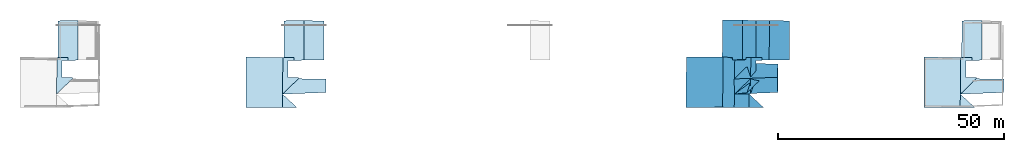
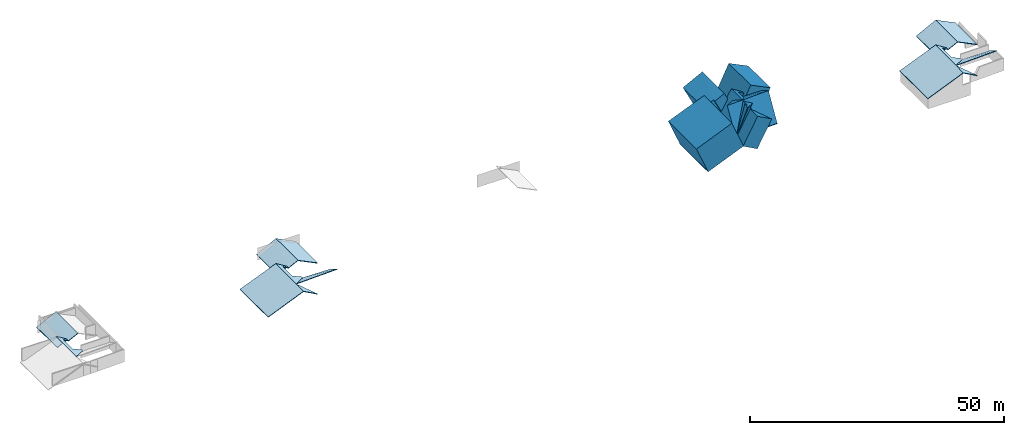
# One storey, part 3 of 4: 7 slabs.
"""IFC4 building model written with IfcOpenShell, lengths in metres."""

from ifc_helpers import new_model, entity, si_unit, converted_unit, frame, frame_2d, origin_with_axes, place, context, subcontext, project, spatial, polygons, element, save


model = new_model("IFC4")

# Units and contexts
model_context = context("Model", 3, precision=1e-05, world=origin_with_axes())
plan_context = context("Plan", 2, precision=1e-05, world=frame_2d((0.0, 0.0, 0.0), x_axis=(1.0, 0.0, 0.0)))
body_context = subcontext(model_context, "Body", "Model", "MODEL_VIEW")
ifc_project = project(units=[converted_unit("PLANEANGLEUNIT", "degree", entity("IfcReal", 0.0174532925199433), si_unit("PLANEANGLEUNIT", "RADIAN"), dimensions=[0, 0, 0, 0, 0, 0, 0]), si_unit("AREAUNIT", "SQUARE_METRE"), si_unit("VOLUMEUNIT", "CUBIC_METRE"), si_unit("LENGTHUNIT", "METRE")], contexts=[model_context, plan_context])

# Site, building, storey
site_placement = place(None, origin_with_axes())
site = spatial("IfcSite", under=ifc_project, at=site_placement)
building_placement = place(site_placement, origin_with_axes())
building = spatial("IfcBuilding", under=site, at=building_placement, Name="Building")
storey_placement = place(building_placement, frame((0.0, 0.0, 3.0), z_axis=(0.0, 0.0, 1.0), x_axis=(1.0, 0.0, 0.0)))
storey = spatial("IfcBuildingStorey", under=building, at=storey_placement, Name="Dachgeschoss")

# Slabs
slab_1_placement = place(storey_placement, frame((26.8203887939453, 9.78442668914795, -2.06702888011932), z_axis=(0.0, 0.0, 1.0), x_axis=(1.0, 0.0, 0.0)))
element("IfcSlab", 1, at=slab_1_placement, inside=storey, Name="dach_wohnen_w", PredefinedType="ROOF", context=body_context, shape_type="Tessellation", body=[
    polygons([(-18.3055820465088, -6.04181098937988, 5.09152317047119), (-14.7738656997681, -2.62468528747559, 3.28549098968506), (-18.2124099731445, 2.09556102752686, 5.02737331390381), (-17.0658378601074, 1.3901504278183, 4.31534337997437), (-15.7722063064575, 1.39000952243805, 3.52441787719727), (-15.7722063064575, 2.09556126594543, 3.52441787719727), (-14.7738656997681, -2.33506321907043, 3.28549098968506), (-17.0658378601074, -2.33499145507813, 4.31534337997437), (-18.2124099731445, 2.09556102752686, 4.87737321853638), (-18.3055820465088, -6.04181098937988, 4.94152307510376), (-14.7738656997681, -2.62468528747559, 3.13549089431763), (-15.7722063064575, 2.09556126594543, 3.37441778182983), (-17.0658378601074, 1.3901504278183, 4.16534328460693), (-15.7722063064575, 1.39000952243805, 3.37441778182983), (-14.7738656997681, -2.33506321907043, 3.13549089431763), (-17.0658378601074, -2.33499145507813, 4.16534328460693)], [[[1, 3, 8]], [[16, 13, 9]], [[7, 8, 16, 15]], [[5, 6, 12, 14]], [[6, 3, 9, 12]], [[3, 10, 9]], [[4, 16, 8]], [[2, 7, 15, 11]], [[4, 5, 14, 13]], [[1, 2, 11, 10]], [[3, 6, 4]], [[6, 5, 4]], [[7, 2, 8]], [[2, 1, 8]], [[3, 4, 8]], [[10, 11, 16]], [[11, 15, 16]], [[14, 12, 13]], [[12, 9, 13]], [[10, 16, 9]], [[3, 1, 10]], [[4, 13, 16]]]),
])
slab_2_placement = place(storey_placement, frame((11.5073595046997, 19.0338859558105, -0.612094879150391), z_axis=(0.0, 0.0, 1.0), x_axis=(1.0, 0.0, 0.0)))
element("IfcSlab", 2, at=slab_2_placement, inside=storey, Name="dach_so", PredefinedType="ROOF", context=body_context, shape_type="Tessellation", body=[
    polygons([(-2.97228264808655, -7.43174934387207, 0.821340084075928), (1.74949443340302, -7.77036571502686, 3.06659126281738), (-2.62752819061279, 0.947076737880707, 0.736433267593384), (1.80188846588135, 0.977355897426605, 2.99584007263184), (-0.459177732467651, -7.85944890975952, 2.06948375701904), (-2.70927309989929, -7.33231735229492, 0.930184245109558), (-0.459176629781723, -7.35307836532593, 2.06948399543762), (1.74949443340302, -7.77036571502686, 2.91659116744995), (1.80188846588135, 0.977355897426605, 2.8458399772644), (-2.62752819061279, 0.947076737880707, 0.586433291435242), (-2.70927309989929, -7.33231735229492, 0.780184268951416), (-0.459177732467651, -7.85944890975952, 1.9194837808609), (-0.459176629781723, -7.35307836532593, 1.91948401927948)], [[[2, 5, 7]], [[9, 10, 13]], [[6, 7, 13, 11]], [[4, 3, 10, 9]], [[3, 6, 11, 10]], [[5, 2, 8, 12]], [[7, 5, 12, 13]], [[2, 4, 9, 8]], [[7, 6, 3]], [[3, 4, 7]], [[4, 2, 7]], [[10, 11, 13]], [[13, 12, 8]], [[8, 9, 13]]]),
])
slab_3_placement = place(storey_placement, frame((26.8203887939453, 9.78442668914795, -2.06702888011932), z_axis=(0.0, 0.0, 1.0), x_axis=(1.0, 0.0, 0.0)))
element("IfcSlab", 3, at=slab_3_placement, inside=storey, Name="dach_wohnen_w", PredefinedType="ROOF", context=body_context, shape_type="Tessellation", body=[
    polygons([(-18.3055820465088, -6.04181098937988, 5.09152317047119), (-14.7738656997681, -2.62468528747559, 3.28549098968506), (-18.2124099731445, 2.09556102752686, 5.02737331390381), (-17.0658378601074, 1.3901504278183, 4.31534337997437), (-15.7722063064575, 1.39000952243805, 3.52441787719727), (-15.7722063064575, 2.09556126594543, 3.52441787719727), (-14.7738656997681, -2.33506321907043, 3.28549098968506), (-17.0658378601074, -2.33499145507813, 4.31534337997437), (-18.2124099731445, 2.09556102752686, 4.87737321853638), (-18.3055820465088, -6.04181098937988, 4.94152307510376), (-14.7738656997681, -2.62468528747559, 3.13549089431763), (-15.7722063064575, 2.09556126594543, 3.37441778182983), (-17.0658378601074, 1.3901504278183, 4.16534328460693), (-15.7722063064575, 1.39000952243805, 3.37441778182983), (-14.7738656997681, -2.33506321907043, 3.13549089431763), (-17.0658378601074, -2.33499145507813, 4.16534328460693)], [[[1, 3, 8]], [[16, 13, 9]], [[7, 8, 16, 15]], [[5, 6, 12, 14]], [[6, 3, 9, 12]], [[3, 10, 9]], [[4, 16, 8]], [[2, 7, 15, 11]], [[4, 5, 14, 13]], [[1, 2, 11, 10]], [[3, 6, 4]], [[6, 5, 4]], [[7, 2, 8]], [[2, 1, 8]], [[3, 4, 8]], [[10, 11, 16]], [[11, 15, 16]], [[14, 12, 13]], [[12, 9, 13]], [[10, 16, 9]], [[3, 1, 10]], [[4, 13, 16]]]),
])
slab_4_placement = place(storey_placement, frame((64.0933456420898, 19.4814624786377, 1.75806331634521), z_axis=(0.835473120212555, 6.05244707685415e-08, 0.549531161785126), x_axis=(0.549531161785126, 1.1225321117081e-07, -0.835473120212555)))
element("IfcSlab", 4, at=slab_4_placement, inside=storey, Name="dach_sw", PredefinedType="ROOF", context=body_context, shape_type="Tessellation", body=[
    polygons([(-1.04153060913086, -8.217942237854, -0.316155582666397), (3.25821256637573, -8.2083625793457, 2.20982432365417), (3.28126811981201, 0.463787794113159, 2.21388936042786), (-0.828306198120117, 0.529778599739075, -0.393690884113312), (-0.916209638118744, -8.217942237854, -0.398585289716721), (3.40658903121948, 0.463787794113159, 2.13145971298218), (3.38353371620178, -8.2083625793457, 2.1273946762085), (-0.953627169132233, 0.529778599739075, -0.311261177062988), (-5.69820785522461, -7.55826425552368, -12.5883283615112), (-5.57288694381714, -7.55826425552368, -12.6707582473755), (-4.0188570022583, -7.60147333145142, -3.92218780517578), (-3.89353585243225, -7.60147333145142, -4.00461769104004), (-5.79283761978149, -18.7311210632324, -12.5506534576416), (-5.66751670837402, -18.7311210632324, -12.6330833435059), (-4.03650379180908, -18.7027893066406, -4.06271934509277), (-4.16182422637939, -18.7027893066406, -3.98029041290283), (-4.12365627288818, -15.7388458251953, -3.96478462219238), (-2.79389953613281, -12.0320262908936, -3.35554599761963), (-4.01885890960693, -7.60147333145142, -3.92219352722168), (-3.8935375213623, -7.60147333145142, -4.00462341308594), (-2.66857814788818, -12.0320262908936, -3.43797588348389), (-2.66857814788818, -8.30688381195068, -3.43797588348389), (-0.67397403717041, -12.0320978164673, -2.00660037994385), (-0.548652648925781, -12.0320978164673, -2.08903026580811), (-1.42221164703369, -8.30702495574951, -2.70938968658447), (-1.29689025878906, -8.30702495574951, -2.79181957244873), (-1.42221164703369, -7.60147380828857, -2.70938968658447), (-1.29689025878906, -7.60147380828857, -2.79181957244873), (-3.99833488464355, -15.7388458251953, -4.04721355438232), (-2.79389953613281, -8.30688381195068, -3.35554599761963), (-0.67397403717041, -12.321720123291, -2.00660037994385), (-0.548652648925781, -12.321720123291, -2.08903026580811), (-4.1236515045166, -15.7388467788696, -3.96478033065796), (-0.673971772193909, -12.3217210769653, -2.00659704208374), (1.15773463249207, -15.3621768951416, 4.05553722381592), (-3.99833059310913, -15.7388467788696, -4.04720973968506), (1.28305554389954, -15.3621768951416, 3.97310733795166), (-0.548650741577148, -12.3217210769653, -2.089026927948), (2.71919560432434, -12.414342880249, 3.105712890625), (2.84451651573181, -12.414342880249, 3.02328300476074), (-0.897188901901245, -18.6908473968506, -2.2620792388916), (-4.12365484237671, -15.7388458251953, -3.96478271484375), (-4.16182661056519, -18.7027893066406, -3.98029661178589), (-3.99833369255066, -15.7388458251953, -4.04721260070801), (-4.03650569915771, -18.7027893066406, -4.06272649765015), (-0.771867752075195, -18.6908473968506, -2.34450912475586), (-1.0415301322937, -8.217942237854, -0.316158056259155), (-1.42220735549927, -7.80065488815308, -2.70938539505005), (-1.42220783233643, -8.30702590942383, -2.70938634872437), (-0.828305125236511, 0.529779374599457, -0.393693447113037), (-1.2968864440918, -7.80065488815308, -2.79181504249573), (-1.3747341632843, 0.499500572681427, -5.33596706390381), (-1.70685124397278, -7.77989339828491, -5.21536159515381), (-1.58153033256531, -7.77989339828491, -5.29779148101807), (-0.953626275062561, 0.529779374599457, -0.311263561248779), (-1.50005507469177, 0.499500572681427, -5.25353765487671), (-1.29688680171967, -8.30702590942383, -2.79181623458862), (-0.916208982467651, -8.217942237854, -0.398587703704834)], [[[5, 6, 7]], [[6, 4, 8, 3]], [[4, 5, 1, 8]], [[1, 3, 8]], [[7, 2, 1, 5]], [[3, 2, 7, 6]], [[15, 13, 14]], [[9, 11, 12, 10]], [[9, 10, 14, 13]], [[16, 15, 12, 11]], [[9, 16, 11]], [[10, 15, 14]], [[30, 19, 18]], [[26, 25, 30, 22]], [[30, 18, 21, 22]], [[31, 29, 32]], [[24, 23, 31, 32]], [[19, 20, 29, 17]], [[27, 28, 20, 19]], [[23, 24, 21, 18]], [[32, 21, 24]], [[38, 37, 36]], [[21, 29, 20]], [[27, 25, 26, 28]], [[35, 34, 33]], [[35, 37, 40, 39]], [[34, 38, 36, 33]], [[39, 40, 38, 34]], [[37, 35, 33, 36]], [[41, 42, 43]], [[44, 46, 45]], [[41, 45, 46]], [[46, 44, 42, 41]], [[43, 42, 44, 45]], [[49, 58, 47]], [[52, 56, 55, 50]], [[18, 31, 23]], [[53, 54, 51, 48]], [[47, 58, 50, 55]], [[54, 53, 56, 52]], [[56, 53, 48]], [[51, 54, 52]], [[48, 51, 57, 49]], [[5, 4, 6]], [[1, 2, 3]], [[15, 16, 13]], [[9, 13, 16]], [[10, 12, 15]], [[30, 25, 27]], [[19, 17, 18]], [[30, 27, 19]], [[31, 17, 29]], [[32, 29, 21]], [[38, 40, 37]], [[20, 28, 22]], [[28, 26, 22]], [[22, 21, 20]], [[35, 39, 34]], [[41, 43, 45]], [[49, 57, 58]], [[18, 17, 31]], [[48, 49, 47]], [[47, 55, 48]], [[55, 56, 48]], [[52, 50, 51]], [[50, 58, 51]], [[58, 57, 51]]]),
])
slab_5_placement = place(storey_placement, frame((11.5073595046997, 19.0338859558105, -0.612094879150391), z_axis=(0.0, 0.0, 1.0), x_axis=(1.0, 0.0, 0.0)))
element("IfcSlab", 5, at=slab_5_placement, inside=storey, Name="dach_so", PredefinedType="ROOF", context=body_context, shape_type="Tessellation", body=[
    polygons([(-2.97228264808655, -7.43174934387207, 0.821340084075928), (1.74949443340302, -7.77036571502686, 3.06659126281738), (-2.62752819061279, 0.947076737880707, 0.736433267593384), (1.80188846588135, 0.977355897426605, 2.99584007263184), (-0.459177732467651, -7.85944890975952, 2.06948375701904), (-2.70927309989929, -7.33231735229492, 0.930184245109558), (-0.459176629781723, -7.35307836532593, 2.06948399543762), (1.74949443340302, -7.77036571502686, 2.91659116744995), (1.80188846588135, 0.977355897426605, 2.8458399772644), (-2.62752819061279, 0.947076737880707, 0.586433291435242), (-2.70927309989929, -7.33231735229492, 0.780184268951416), (-0.459177732467651, -7.85944890975952, 1.9194837808609), (-0.459176629781723, -7.35307836532593, 1.91948401927948)], [[[2, 5, 7]], [[9, 10, 13]], [[6, 7, 13, 11]], [[4, 3, 10, 9]], [[3, 6, 11, 10]], [[5, 2, 8, 12]], [[7, 5, 12, 13]], [[2, 4, 9, 8]], [[7, 6, 3]], [[3, 4, 7]], [[4, 2, 7]], [[10, 11, 13]], [[13, 12, 8]], [[8, 9, 13]]]),
])
slab_6_placement = place(storey_placement, frame((164.093353271484, 19.4814624786377, 1.75806331634521), z_axis=(0.835473120212555, 6.05244707685415e-08, 0.549531161785126), x_axis=(0.549531161785126, 1.1225321117081e-07, -0.835473120212555)))
element("IfcSlab", 6, at=slab_6_placement, inside=storey, Name="dach_sw", PredefinedType="ROOF", context=body_context, shape_type="Tessellation", body=[
    polygons([(-1.04153060913086, -8.217942237854, -0.316155582666397), (3.25821256637573, -8.2083625793457, 2.20982432365417), (3.28126811981201, 0.463787794113159, 2.21388936042786), (-0.828306198120117, 0.529778599739075, -0.393690884113312), (-0.916209638118744, -8.217942237854, -0.398585289716721), (3.40658903121948, 0.463787794113159, 2.13145971298218), (3.38353371620178, -8.2083625793457, 2.1273946762085), (-0.953627169132233, 0.529778599739075, -0.311261177062988), (-5.69820785522461, -7.55826425552368, -12.5883283615112), (-5.57288694381714, -7.55826425552368, -12.6707582473755), (-4.0188570022583, -7.60147333145142, -3.92218780517578), (-3.89353585243225, -7.60147333145142, -4.00461769104004), (-5.79283761978149, -18.7311210632324, -12.5506534576416), (-5.66751670837402, -18.7311210632324, -12.6330833435059), (-4.03650379180908, -18.7027893066406, -4.06271934509277), (-4.16182422637939, -18.7027893066406, -3.98029041290283), (-4.12365627288818, -15.7388458251953, -3.96478462219238), (-2.79389953613281, -12.0320262908936, -3.35554599761963), (-4.01885890960693, -7.60147333145142, -3.92219352722168), (-3.8935375213623, -7.60147333145142, -4.00462341308594), (-2.66857814788818, -12.0320262908936, -3.43797588348389), (-2.66857814788818, -8.30688381195068, -3.43797588348389), (-0.67397403717041, -12.0320978164673, -2.00660037994385), (-0.548652648925781, -12.0320978164673, -2.08903026580811), (-1.42221164703369, -8.30702495574951, -2.70938968658447), (-1.29689025878906, -8.30702495574951, -2.79181957244873), (-1.42221164703369, -7.60147380828857, -2.70938968658447), (-1.29689025878906, -7.60147380828857, -2.79181957244873), (-3.99833488464355, -15.7388458251953, -4.04721355438232), (-2.79389953613281, -8.30688381195068, -3.35554599761963), (-0.67397403717041, -12.321720123291, -2.00660037994385), (-0.548652648925781, -12.321720123291, -2.08903026580811), (-4.1236515045166, -15.7388467788696, -3.96478033065796), (-0.673971772193909, -12.3217210769653, -2.00659704208374), (1.15773463249207, -15.3621768951416, 4.05553722381592), (-3.99833059310913, -15.7388467788696, -4.04720973968506), (1.28305554389954, -15.3621768951416, 3.97310733795166), (-0.548650741577148, -12.3217210769653, -2.089026927948), (2.71919560432434, -12.414342880249, 3.105712890625), (2.84451651573181, -12.414342880249, 3.02328300476074), (-0.897188901901245, -18.6908473968506, -2.2620792388916), (-4.12365484237671, -15.7388458251953, -3.96478271484375), (-4.16182661056519, -18.7027893066406, -3.98029661178589), (-3.99833369255066, -15.7388458251953, -4.04721260070801), (-4.03650569915771, -18.7027893066406, -4.06272649765015), (-0.771867752075195, -18.6908473968506, -2.34450912475586), (-1.0415301322937, -8.217942237854, -0.316158056259155), (-1.42220735549927, -7.80065488815308, -2.70938539505005), (-1.42220783233643, -8.30702590942383, -2.70938634872437), (-0.828305125236511, 0.529779374599457, -0.393693447113037), (-1.2968864440918, -7.80065488815308, -2.79181504249573), (-1.3747341632843, 0.499500572681427, -5.33596706390381), (-1.70685124397278, -7.77989339828491, -5.21536159515381), (-1.58153033256531, -7.77989339828491, -5.29779148101807), (-0.953626275062561, 0.529779374599457, -0.311263561248779), (-1.50005507469177, 0.499500572681427, -5.25353765487671), (-1.29688680171967, -8.30702590942383, -2.79181623458862), (-0.916208982467651, -8.217942237854, -0.398587703704834), (-4.12365627288818, -15.7388458251953, -3.96478462219238), (-2.79389953613281, -12.0320262908936, -3.35554599761963), (-4.01885890960693, -7.60147333145142, -3.92219352722168), (-1.42221164703369, -8.30702495574951, -2.70938968658447), (-2.79389953613281, -8.30688381195068, -3.35554599761963), (-1.42221164703369, -7.60147380828857, -2.70938968658447), (-4.47271633148193, -8.19906902313232, 5.48155498504639), (-0.172973394393921, -8.18948936462402, 8.00753498077393), (-0.149917840957642, 0.48266139626503, 8.01159954071045), (-4.38481283187866, 0.548652172088623, 5.48644876480103), (-12.313907623291, -7.48886060714722, -11.3176870346069), (-10.6345567703247, -7.53206968307495, -2.65154671669006), (-12.4085378646851, -18.6617164611816, -11.2800121307373), (-10.7775239944458, -18.6333847045898, -2.70964932441711), (-7.70474910736084, -15.4158039093018, 1.73242950439453), (-6.37499237060547, -11.708984375, 2.34166860580444), (-4.25506687164307, -11.7090559005737, 3.69061374664307), (-4.25506687164307, -11.9986782073975, 3.69061422348022), (-9.0290355682373, -12.3786373138428, -0.797283172607422), (-5.57935571670532, -8.96151161193848, 1.16089963912964), (-3.7476499080658, -12.0019674301147, 7.22303438186646), (-2.18618845939636, -9.05413341522217, 6.27320957183838), (-4.03491592407227, -18.6816425323486, 3.69958400726318), (-7.26138114929199, -15.7296409606934, 1.99687957763672), (-7.29955291748047, -18.6935844421387, 1.98136568069458), (-8.10614395141602, -7.66195058822632, -1.8771641254425), (-8.10614490509033, -8.16832160949707, -1.87716507911682), (-7.63756275177002, 0.668483793735504, 0.520957827568054), (-8.18399143218994, 0.638204991817474, -4.42131614685059), (-7.72546625137329, -8.07923793792725, 0.516063213348389), (-8.39078807830811, -7.64118909835815, -4.38314056396484), (-6.94937801361084, -15.741265296936, 2.1509428024292), (-5.61962127685547, -12.0344457626343, 2.76018142700195), (-6.84458065032959, -7.6038932800293, 2.1935338973999), (-4.24793338775635, -8.30944442749023, 3.40633726119995), (-5.61962127685547, -8.30930328369141, 2.76018095016479), (-4.24793338775635, -7.60389375686646, 3.40633773803711)], [[[5, 6, 7]], [[6, 4, 8, 3]], [[4, 5, 1, 8]], [[55, 56, 87, 86]], [[7, 2, 1, 5]], [[3, 2, 7, 6]], [[15, 13, 14]], [[9, 11, 12, 10]], [[9, 10, 14, 13]], [[16, 15, 12, 11]], [[16, 11, 70, 72]], [[10, 15, 14]], [[18, 63, 60]], [[26, 25, 30, 22]], [[30, 18, 21, 22]], [[31, 29, 32]], [[24, 23, 31, 32]], [[19, 20, 29, 17]], [[27, 28, 20, 19]], [[23, 24, 21, 18]], [[32, 21, 24]], [[38, 37, 36]], [[21, 29, 20]], [[27, 25, 26, 28]], [[56, 53, 89, 87]], [[35, 37, 40, 39]], [[34, 38, 36, 33]], [[39, 40, 38, 34]], [[37, 35, 33, 36]], [[35, 39, 80, 79]], [[44, 46, 45]], [[41, 45, 46]], [[46, 44, 42, 41]], [[43, 42, 44, 45]], [[49, 58, 47]], [[52, 56, 55, 50]], [[39, 34, 78, 80]], [[53, 54, 51, 48]], [[47, 58, 50, 55]], [[54, 53, 56, 52]], [[8, 1, 65, 68]], [[51, 54, 52]], [[48, 51, 57, 49]], [[48, 49, 85, 84]], [[27, 61, 64]], [[25, 64, 62]], [[17, 60, 59]], [[30, 62, 63]], [[19, 59, 61]], [[65, 67, 68]], [[69, 72, 70]], [[79, 78, 77]], [[81, 82, 83]], [[74, 76, 75]], [[87, 89, 84]], [[94, 92, 91]], [[23, 74, 75]], [[41, 82, 81]], [[59, 60, 91, 90]], [[31, 23, 75, 76]], [[3, 8, 68, 67]], [[43, 41, 81, 83]], [[61, 59, 90, 92]], [[34, 33, 77, 78]], [[49, 47, 88, 85]], [[63, 62, 93, 94]], [[18, 17, 73, 74]], [[33, 35, 79, 77]], [[64, 61, 92, 95]], [[53, 48, 84, 89]], [[60, 63, 94, 91]], [[47, 55, 86, 88]], [[11, 9, 69, 70]], [[17, 31, 76, 73]], [[1, 2, 66, 65]], [[62, 64, 95, 93]], [[9, 13, 71, 69]], [[42, 43, 83, 82]], [[16, 71, 13]], [[2, 3, 67, 66]], [[5, 4, 6]], [[15, 16, 13]], [[10, 12, 15]], [[18, 30, 63]], [[31, 17, 29]], [[32, 29, 21]], [[38, 40, 37]], [[20, 28, 22]], [[28, 26, 22]], [[22, 21, 20]], [[41, 43, 45]], [[49, 57, 58]], [[52, 50, 51]], [[50, 58, 51]], [[58, 57, 51]], [[27, 19, 61]], [[25, 27, 64]], [[17, 18, 60]], [[30, 25, 62]], [[19, 17, 59]], [[65, 66, 67]], [[69, 71, 72]], [[79, 80, 78]], [[74, 73, 76]], [[84, 85, 88]], [[88, 86, 84]], [[86, 87, 84]], [[94, 93, 95]], [[92, 90, 91]], [[94, 95, 92]], [[23, 18, 74]], [[41, 42, 82]], [[16, 72, 71]]]),
])
slab_7_placement = place(storey_placement, frame((214.093353271484, 19.4814624786377, 1.75806331634521), z_axis=(0.835473120212555, 6.05244707685415e-08, 0.549531161785126), x_axis=(0.549531161785126, 1.1225321117081e-07, -0.835473120212555)))
element("IfcSlab", 7, at=slab_7_placement, inside=storey, Name="dach_sw.004", PredefinedType="ROOF", context=body_context, shape_type="Tessellation", body=[
    polygons([(-1.04153060913086, -8.217942237854, -0.316155582666397), (3.25821256637573, -8.2083625793457, 2.20982432365417), (3.28126811981201, 0.463787794113159, 2.21388936042786), (-0.828306198120117, 0.529778599739075, -0.393690884113312), (-0.916209638118744, -8.217942237854, -0.398585289716721), (3.40658903121948, 0.463787794113159, 2.13145971298218), (3.38353371620178, -8.2083625793457, 2.1273946762085), (-0.953627169132233, 0.529778599739075, -0.311261177062988), (-5.69820785522461, -7.55826425552368, -12.5883283615112), (-5.57288694381714, -7.55826425552368, -12.6707582473755), (-4.0188570022583, -7.60147333145142, -3.92218780517578), (-3.89353585243225, -7.60147333145142, -4.00461769104004), (-5.79283761978149, -18.7311210632324, -12.5506534576416), (-5.66751670837402, -18.7311210632324, -12.6330833435059), (-4.03650379180908, -18.7027893066406, -4.06271934509277), (-4.16182422637939, -18.7027893066406, -3.98029041290283), (-4.12365627288818, -15.7388458251953, -3.96478462219238), (-2.79389953613281, -12.0320262908936, -3.35554599761963), (-4.01885890960693, -7.60147333145142, -3.92219352722168), (-3.8935375213623, -7.60147333145142, -4.00462341308594), (-2.66857814788818, -12.0320262908936, -3.43797588348389), (-2.66857814788818, -8.30688381195068, -3.43797588348389), (-0.67397403717041, -12.0320978164673, -2.00660037994385), (-0.548652648925781, -12.0320978164673, -2.08903026580811), (-1.42221164703369, -8.30702495574951, -2.70938968658447), (-1.29689025878906, -8.30702495574951, -2.79181957244873), (-1.42221164703369, -7.60147380828857, -2.70938968658447), (-1.29689025878906, -7.60147380828857, -2.79181957244873), (-3.99833488464355, -15.7388458251953, -4.04721355438232), (-2.79389953613281, -8.30688381195068, -3.35554599761963), (-0.67397403717041, -12.321720123291, -2.00660037994385), (-0.548652648925781, -12.321720123291, -2.08903026580811), (-4.1236515045166, -15.7388467788696, -3.96478033065796), (-0.673971772193909, -12.3217210769653, -2.00659704208374), (1.15773463249207, -15.3621768951416, 4.05553722381592), (-3.99833059310913, -15.7388467788696, -4.04720973968506), (1.28305554389954, -15.3621768951416, 3.97310733795166), (-0.548650741577148, -12.3217210769653, -2.089026927948), (2.71919560432434, -12.414342880249, 3.105712890625), (2.84451651573181, -12.414342880249, 3.02328300476074), (-0.897188901901245, -18.6908473968506, -2.2620792388916), (-4.12365484237671, -15.7388458251953, -3.96478271484375), (-4.16182661056519, -18.7027893066406, -3.98029661178589), (-3.99833369255066, -15.7388458251953, -4.04721260070801), (-4.03650569915771, -18.7027893066406, -4.06272649765015), (-0.771867752075195, -18.6908473968506, -2.34450912475586), (-1.0415301322937, -8.217942237854, -0.316158056259155), (-1.42220735549927, -7.80065488815308, -2.70938539505005), (-1.42220783233643, -8.30702590942383, -2.70938634872437), (-0.828305125236511, 0.529779374599457, -0.393693447113037), (-1.2968864440918, -7.80065488815308, -2.79181504249573), (-1.3747341632843, 0.499500572681427, -5.33596706390381), (-1.70685124397278, -7.77989339828491, -5.21536159515381), (-1.58153033256531, -7.77989339828491, -5.29779148101807), (-0.953626275062561, 0.529779374599457, -0.311263561248779), (-1.50005507469177, 0.499500572681427, -5.25353765487671), (-1.29688680171967, -8.30702590942383, -2.79181623458862), (-0.916208982467651, -8.217942237854, -0.398587703704834)], [[[5, 6, 7]], [[6, 4, 8, 3]], [[4, 5, 1, 8]], [[1, 3, 8]], [[7, 2, 1, 5]], [[3, 2, 7, 6]], [[15, 13, 14]], [[9, 11, 12, 10]], [[9, 10, 14, 13]], [[16, 15, 12, 11]], [[9, 16, 11]], [[10, 15, 14]], [[30, 19, 18]], [[26, 25, 30, 22]], [[30, 18, 21, 22]], [[31, 29, 32]], [[24, 23, 31, 32]], [[19, 20, 29, 17]], [[27, 28, 20, 19]], [[23, 24, 21, 18]], [[32, 21, 24]], [[38, 37, 36]], [[21, 29, 20]], [[27, 25, 26, 28]], [[35, 34, 33]], [[35, 37, 40, 39]], [[34, 38, 36, 33]], [[39, 40, 38, 34]], [[37, 35, 33, 36]], [[41, 42, 43]], [[44, 46, 45]], [[41, 45, 46]], [[46, 44, 42, 41]], [[43, 42, 44, 45]], [[49, 58, 47]], [[52, 56, 55, 50]], [[18, 31, 23]], [[53, 54, 51, 48]], [[47, 58, 50, 55]], [[54, 53, 56, 52]], [[56, 53, 48]], [[51, 54, 52]], [[48, 51, 57, 49]], [[5, 4, 6]], [[1, 2, 3]], [[15, 16, 13]], [[9, 13, 16]], [[10, 12, 15]], [[30, 25, 27]], [[19, 17, 18]], [[30, 27, 19]], [[31, 17, 29]], [[32, 29, 21]], [[38, 40, 37]], [[20, 28, 22]], [[28, 26, 22]], [[22, 21, 20]], [[35, 39, 34]], [[41, 43, 45]], [[49, 57, 58]], [[18, 17, 31]], [[48, 49, 47]], [[47, 55, 48]], [[55, 56, 48]], [[52, 50, 51]], [[50, 58, 51]], [[58, 57, 51]]]),
])

save(model, "model.ifc")
